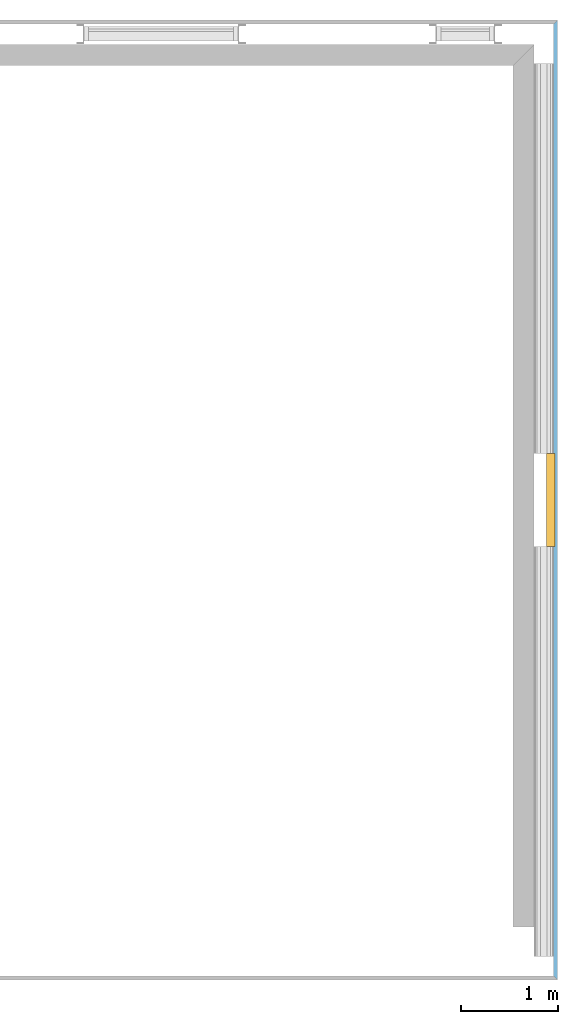
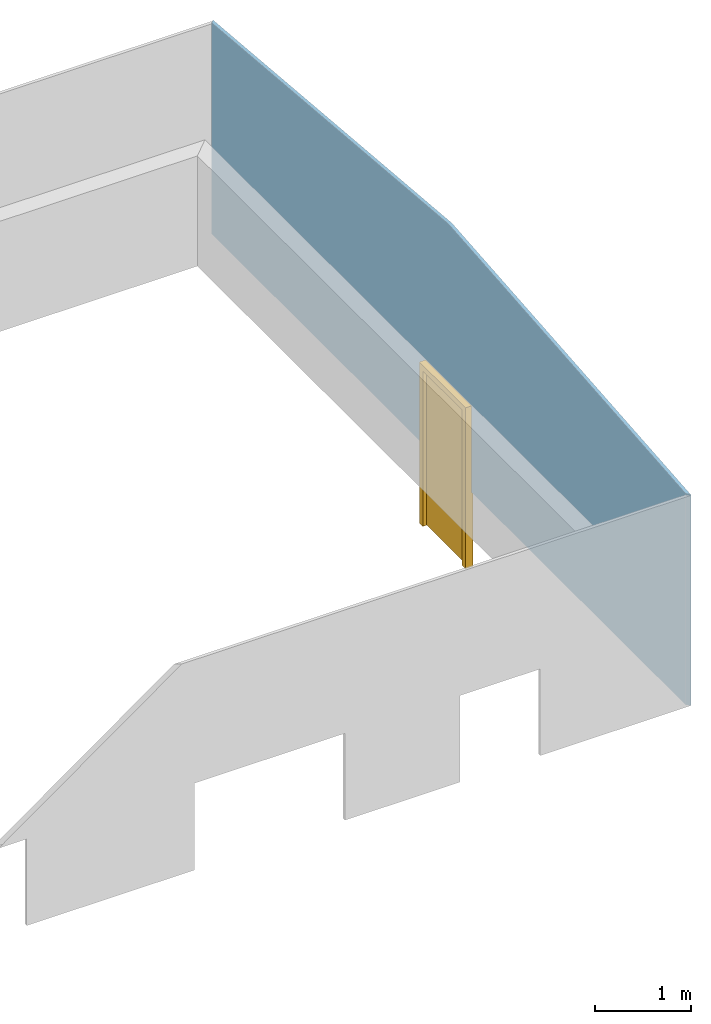
# One storey, part 3 of 4: 1 door, 1 opening, plus 1 element that does not belong to this part.
"""IFC2X3 building model written with IfcOpenShell, lengths in millimetres."""

from ifc_helpers import new_model, entity, si_unit, converted_unit, money_unit, direction, frame, origin_with_axes, place, context, subcontext, project, spatial, polyline, outline, extrude, clip, halfspace, faceted_brep, material, material_list, layer, layer_set, layer_usage, type_object, element, fill, save


model = new_model("IFC2X3")

# Units and contexts
model_context = context("Model", 3, precision=1e-05, world=origin_with_axes(), true_north=direction((0.0, 1.0)))
body_context = subcontext(model_context, "Body", "Model", "MODEL_VIEW")
ifc_project = project(units=[si_unit("LENGTHUNIT", "METRE", prefix="MILLI"), si_unit("AREAUNIT", "SQUARE_METRE"), si_unit("VOLUMEUNIT", "CUBIC_METRE"), converted_unit("PLANEANGLEUNIT", "DEGREE", entity("IfcPlaneAngleMeasure", 0.0174532925199), si_unit("PLANEANGLEUNIT", "RADIAN"), dimensions=[0, 0, 0, 0, 0, 0, 0]), si_unit("SOLIDANGLEUNIT", "STERADIAN"), money_unit("USD"), converted_unit("TIMEUNIT", "Year", entity("IfcTimeMeasure", 31556926.0), si_unit("TIMEUNIT", "SECOND"), dimensions=[0, 0, 0, 0, 0, 0, 0]), si_unit("MASSUNIT", "GRAM"), si_unit("THERMODYNAMICTEMPERATUREUNIT", "DEGREE_CELSIUS"), si_unit("LUMINOUSINTENSITYUNIT", "LUMEN")], contexts=[model_context])

# Site, building, storey
site_placement = place(None, origin_with_axes())
site = spatial("IfcSite", under=ifc_project, at=site_placement, CompositionType="ELEMENT")
building_placement = place(site_placement, origin_with_axes())
building = spatial("IfcBuilding", under=site, at=building_placement, CompositionType="ELEMENT")
storey_placement = place(building_placement, frame((0.0, 0.0, 71700.0), z_axis=(0.0, 0.0, 1.0), x_axis=(1.0, 0.0, 0.0)))
storey = spatial("IfcBuildingStorey", under=building, at=storey_placement, CompositionType="ELEMENT", Elevation=71700.0)

# Wall, opening, door
ifc_material_1 = material(Name="Cladding, Vertical Ribbed")
ifc_layer = layer(ifc_material_1, 40.0, ventilated="UNKNOWN")
ifc_layer_set = layer_set([ifc_layer], Name="Cladding, Vertical Ribbed 40")
ifc_layer_usage = layer_usage(ifc_layer_set, "AXIS2", "POSITIVE", -20.0)
wall_type = type_object("IfcWallType", Name="Basic Wall:480mm Cavity Wall KSW Panel 1000", PredefinedType="STANDARD")
wall_placement = place(storey_placement, frame((16738.0295383, 8527.27990658, 0.0), z_axis=(0.0, 0.0, 1.0), x_axis=(0.0, -1.0, 0.0)))
wall = element("IfcWallStandardCase", 1, at=wall_placement, inside=storey, type_object=wall_type, material=ifc_layer_usage, Name="Basic Wall:480mm Cavity Wall Panel 1000", ObjectType="Basic Wall:480mm Cavity Wall KSW Panel 1000", context=body_context, shape_type="Clipping", body=[
    clip(clip(extrude(outline(polyline([(20.0, -20.0), (9879.59996977, -20.0), (9919.59996977, 20.0), (-20.0, 20.0), (20.0, -20.0)])), origin_with_axes(), (0.0, 0.0, 1.0), 3115.02217894), halfspace(frame((-232.867655757, 0.0, 2661.68948492), z_axis=(0.0871557427477, 0.0, -0.996194698092), x_axis=(0.0, 1.0, 0.0)), True)), halfspace(frame((308.050269008, 0.0, 3521.03068664), z_axis=(-0.0871557427477, 0.0, -0.996194698092), x_axis=(0.0, 1.0, 0.0)), True)),
])
opening_placement = place(wall_placement, frame((4949.7999916, 0.0, -1000.0), z_axis=(0.0, 0.0, 1.0), x_axis=(1.0, 0.0, 0.0)))
opening = element("IfcOpeningElement", 2, at=opening_placement, cuts=wall, Name="Doors_ExtSgl_Flush_Fire_Escape:960x2100mm", context=body_context, shape_type="SweptSolid", body=[
    extrude(outline(polyline([(480.000006706, 0.0), (-480.000006706, 0.0), (-480.000006706, -2100.0), (480.000006706, -2100.0), (480.000006706, 0.0)])), frame((0.0, -20.0, 0.0), z_axis=(0.0, 1.0, 0.0), x_axis=(1.0, 0.0, 0.0)), (0.0, 0.0, 1.0), 40.0),
])
ifc_material_2 = material(Name="IFC Building Material")
ifc_material_list = material_list([ifc_material_2, ifc_material_2])
door_style = type_object("IfcDoorStyle", Name="960x2100mm", ConstructionType="NOTDEFINED", OperationType="SINGLE_SWING_RIGHT", ParameterTakesPrecedence=False, Sizeable=False)
door_placement = place(opening_placement, frame((-480.000006706, 0.0, 0.0), z_axis=(0.0, 0.0, 1.0), x_axis=(1.0, 0.0, 0.0)))
door = element("IfcDoor", 3, at=door_placement, inside=storey, type_object=door_style, material=ifc_material_list, Name="Doors_ExtSgl_Flush_Fire_Escape:960x2100mm", ObjectType="960x2100mm", OverallHeight=2100.0, OverallWidth=960.0, context=body_context, shape_type="Brep", body=[
    faceted_brep([(911.5, -5.0, 54.5), (960.0, -5.0, 54.5), (960.0, -94.0, 54.5), (889.5, -94.0, 54.5), (889.5, -52.0, 54.5), (911.5, -52.0, 54.5), (911.5, -5.0, 2051.5), (48.5, -5.0, 2051.5), (48.5, -5.0, 54.5), (0.0, -5.0, 54.5), (0.0, -5.0, 2100.0), (960.0, -5.0, 2100.0), (960.0, -94.0, 2100.0), (0.0, -94.0, 2100.0), (0.0, -94.0, 54.5), (70.5, -94.0, 54.5), (70.5, -94.0, 2029.5), (889.5, -94.0, 2029.5), (889.5, -52.0, 2029.5), (70.5, -52.0, 2029.5), (70.5, -52.0, 54.5), (48.5, -52.0, 54.5), (48.5, -52.0, 2051.5), (911.5, -52.0, 2051.5)], [[[0, 1, 2, 3, 4, 5]], [[1, 0, 6, 7, 8, 9, 10, 11]], [[2, 1, 11, 12]], [[3, 2, 12, 13, 14, 15, 16, 17]], [[4, 3, 17, 18]], [[5, 4, 18, 19, 20, 21, 22, 23]], [[0, 5, 23, 6]], [[6, 23, 22, 7]], [[7, 22, 21, 8]], [[8, 21, 20, 15, 14, 9]], [[13, 10, 9, 14]], [[12, 11, 10, 13]], [[19, 16, 15, 20]], [[18, 17, 16, 19]]]),
    faceted_brep([(908.5, -49.0, 58.5), (908.5, -49.0, 2048.5), (50.574970588, -49.0, 2048.5), (50.574970588, -49.0, 58.5), (908.5, -5.0, 58.5), (908.5, -5.0, 2048.5), (50.574970588, -5.0, 2048.5), (50.574970588, -5.0, 58.5)], [[[0, 1, 2, 3]], [[1, 0, 4, 5]], [[2, 1, 5, 6]], [[3, 2, 6, 7]], [[0, 3, 7, 4]], [[4, 7, 6, 5]]]),
])
fill(opening, door)

save(model, "model.ifc")
